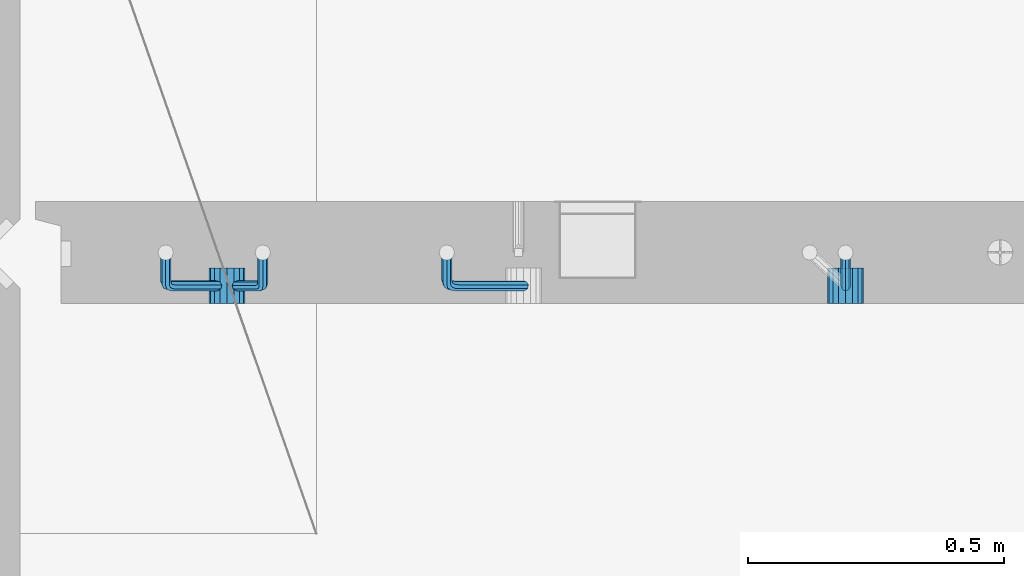
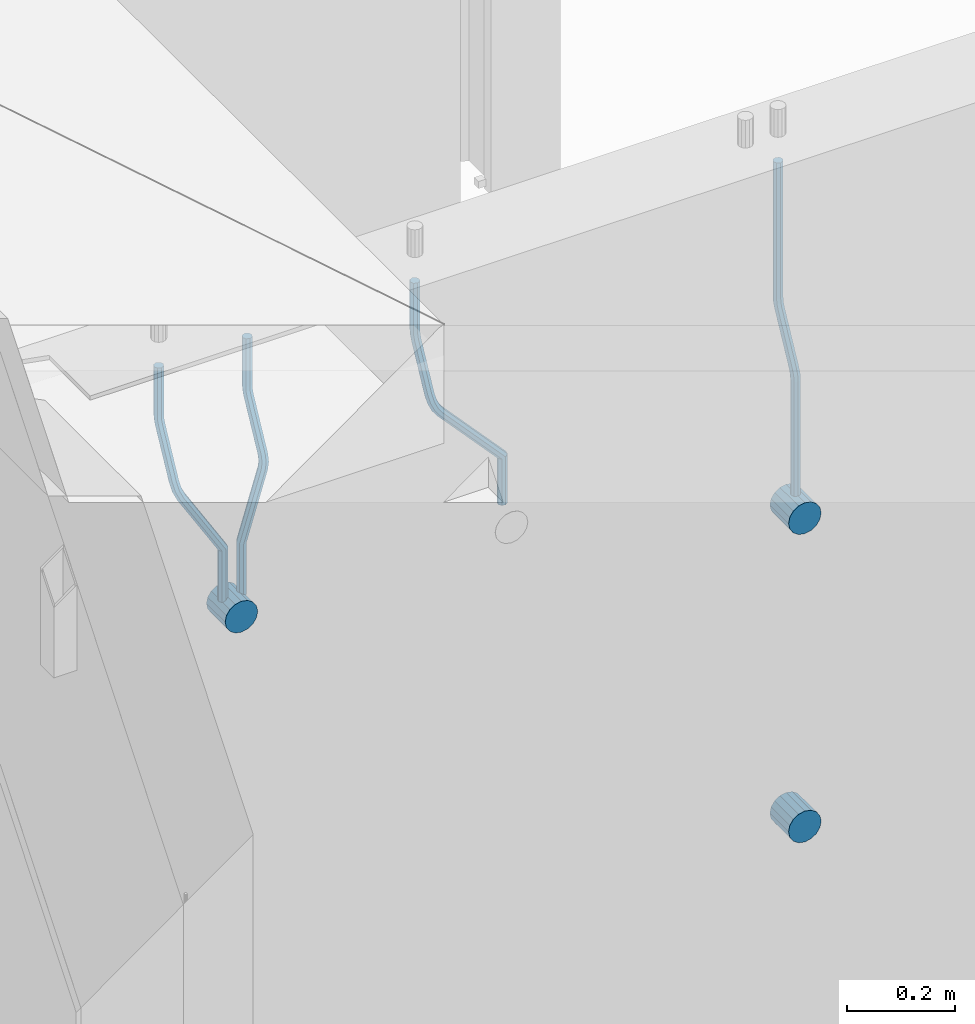
# One storey, part 130 of 309: 7 beams, 1 element without a shape of its own.
"""IFC2X3 building model written with IfcOpenShell, lengths in millimetres."""

from ifc_helpers import new_model, si_unit, frame, origin_with_axes, place, context, subcontext, project, spatial, faceted_brep, material, type_object, element, aggregate, save


model = new_model("IFC2X3")

# Units and contexts
model_context = context("Model", 3, precision=1e-05, world=origin_with_axes())
body_context = subcontext(model_context, "Body", "Model", "MODEL_VIEW")
ifc_project = project(units=[si_unit("LENGTHUNIT", "METRE", prefix="MILLI"), si_unit("AREAUNIT", "SQUARE_METRE"), si_unit("VOLUMEUNIT", "CUBIC_METRE"), si_unit("MASSUNIT", "GRAM", prefix="KILO"), si_unit("TIMEUNIT", "SECOND"), si_unit("PLANEANGLEUNIT", "RADIAN"), si_unit("SOLIDANGLEUNIT", "STERADIAN"), si_unit("THERMODYNAMICTEMPERATUREUNIT", "DEGREE_CELSIUS"), si_unit("LUMINOUSINTENSITYUNIT", "LUMEN")], contexts=[model_context])

# Site, building, storey
site_placement = place(None, origin_with_axes())
site = spatial("IfcSite", under=ifc_project, at=site_placement, CompositionType="ELEMENT")
building_placement = place(site_placement, origin_with_axes())
building = spatial("IfcBuilding", under=site, at=building_placement, CompositionType="ELEMENT")
storey_placement = place(building_placement, origin_with_axes())
storey = spatial("IfcBuildingStorey", under=building, at=storey_placement, Name="7", CompositionType="ELEMENT", Elevation=0.0)

# Assembly, beams
assembly_placement = place(storey_placement, origin_with_axes())
assembly = element("IfcElementAssembly", 1, at=assembly_placement, inside=storey, AssemblyPlace="NOTDEFINED", PredefinedType="REINFORCEMENT_UNIT")
ifc_material = material()
beam_type_1 = type_object("IfcBeamType", Name="D20", PredefinedType="NOTDEFINED")
beam_1_placement = place(assembly_placement, frame((9615.0034031366, 16979.9000008034, 102407.5), z_axis=(-0.000415599999849952, -0.999999913638316, 0.0), x_axis=(0.0, 0.0, -1.0)))
beam_1 = element("IfcBeam", 2, at=beam_1_placement, type_object=beam_type_1, material=ifc_material, Name="JM20", ObjectType="D20", context=body_context, shape_type="Brep", body=[
    faceted_brep([(0.0, -10.0, 0.0), (-4.19531716033816e-08, -7.07106781186667, -7.07106781187031), (308.817759199839, -7.07106784567077, -7.07106781098628), (308.817759199388, -10.0000000315576, 1.18961906991899e-09), (0.0, 0.0, -10.0), (308.817759200625, -3.38059180648997e-08, -9.99999999911961), (4.196772351861e-08, 7.07106781186303, -7.07106781186667), (308.817759201396, 7.07106777806075, -7.07106781098992), (0.0, 10.0, 0.0), (308.817759201687, 9.99999996619408, 8.76752892509103e-10), (4.196772351861e-08, 7.07106781185939, 7.07106781185939), (308.817759201353, 7.07106777805893, 7.07106781273978), (0.0, 0.0, 10.0), (308.817759200567, -3.38059180648997e-08, 10.0000000008768), (-4.19531716033816e-08, -7.07106781187031, 7.07106781185939), (308.817759199781, -7.07106784567259, 7.07106781274342), (323.108969574154, 0.000717635259206872, -8.27316123493802), (322.412036484602, -7.07038517474393, -5.42844102338131), (320.72809124495, -9.99940192615759, 1.43915193649809), (319.043566138222, -7.07055433041933, 8.30667482965873), (318.345233125816, 0.000478413006931078, 11.1512258851908), (319.042166215368, 7.07158122300643, 8.30650567364501), (320.726111455049, 10.0005979744237, 1.4389127137656), (322.410636561748, 7.07175037869092, -5.42861017940231), (335.221090258594, 7.07375888522984, -0.59577927861028), (336.577559329642, 0.00282932867594354, -3.19204402394098), (331.949003496353, 10.0023575726736, 5.67282516818887), (328.678043090971, 7.07309199865631, 11.9417058486688), (327.324293285914, 0.00188620863991673, 14.5386374811205), (328.680762356948, -7.06904334791398, 11.9423727357971), (331.952849119407, -9.99764203791528, 5.67376828873239), (335.223809524556, -7.06837646134409, -0.59511239150379), (438.031978881656, -7.04607830785426, 53.0582885393342), (434.761018476231, -9.97534387865016, 59.3271692200688), (439.385728686641, 0.0251274821457628, 50.4613569068679), (438.02925961549, 7.0960570387233, 53.0576216521513), (434.757172853177, 10.0246557262235, 59.326226098925), (431.486212447766, 7.0953901522571, 65.5951067794085), (430.132462642781, 0.0241843622607121, 68.1920384118748), (431.488931713931, -7.04674519431865, 65.5957736665914), (448.364788846782, 0.0265352911246737, 53.8487685030559), (447.667855771331, -7.04456751813632, 56.6934887198913), (445.983910537514, -9.97358426776555, 63.5610816819462), (444.29938542498, -7.04473667025195, 70.428604572935), (443.601052398531, 0.0262960739091795, 73.2731556232175), (444.297985473939, 7.09739888316835, 70.4284354063821), (445.981930707741, 10.0264156328012, 63.5608424443053), (447.666455820276, 7.09756803528398, 56.6933195533311), (457.892262743961, 7.0980815803614, 57.9289265681182), (457.892262772089, 0.0270137655697908, 54.999994387068), (457.892262732348, 10.0270137755506, 64.9999943770345), (457.892262744092, 7.09808159448221, 72.0710621918224), (457.89226277222, 0.0270137855477515, 74.9999943870425), (457.89226280032, -7.04405402924385, 72.0710622060069), (457.892262811918, -9.97298622770904, 64.9999943967923), (457.892262800189, -7.04405404336103, 57.9289265822954), (717.500000028129, -7.04405301280349, 57.928926581666), (717.500000039799, -9.97298519384276, 64.9999943964685), (717.499999999956, 0.0270147961218754, 54.999994386435), (717.499999971798, 7.09808261092803, 57.9289265674743), (717.499999960128, 10.0270148061572, 64.9999943763978), (717.499999971813, 7.09808262511979, 72.071062191204), (717.499999999985, 0.0270148161926045, 74.999994386435), (717.500000028143, -7.04405299861173, 72.0710622053957)], [[[0, 1, 2, 3]], [[1, 4, 5, 2]], [[4, 6, 7, 5]], [[6, 8, 9, 7]], [[8, 10, 11, 9]], [[10, 12, 13, 11]], [[12, 14, 15, 13]], [[14, 0, 3, 15]], [[14, 12, 10, 8, 6, 4, 1, 0]], [[2, 5, 16, 17]], [[3, 2, 17, 18]], [[15, 3, 18, 19]], [[13, 15, 19, 20]], [[11, 13, 20, 21]], [[9, 11, 21, 22]], [[7, 9, 22, 23]], [[5, 7, 23, 16]], [[23, 24, 25, 16]], [[22, 26, 24, 23]], [[21, 27, 26, 22]], [[20, 28, 27, 21]], [[19, 29, 28, 20]], [[18, 30, 29, 19]], [[17, 31, 30, 18]], [[16, 25, 31, 17]], [[30, 31, 32, 33]], [[31, 25, 34, 32]], [[25, 24, 35, 34]], [[24, 26, 36, 35]], [[26, 27, 37, 36]], [[27, 28, 38, 37]], [[28, 29, 39, 38]], [[29, 30, 33, 39]], [[32, 34, 40, 41]], [[33, 32, 41, 42]], [[39, 33, 42, 43]], [[38, 39, 43, 44]], [[37, 38, 44, 45]], [[36, 37, 45, 46]], [[35, 36, 46, 47]], [[34, 35, 47, 40]], [[47, 48, 49, 40]], [[46, 50, 48, 47]], [[45, 51, 50, 46]], [[44, 52, 51, 45]], [[43, 53, 52, 44]], [[42, 54, 53, 43]], [[41, 55, 54, 42]], [[40, 49, 55, 41]], [[54, 55, 56, 57]], [[55, 49, 58, 56]], [[49, 48, 59, 58]], [[48, 50, 60, 59]], [[50, 51, 61, 60]], [[51, 52, 62, 61]], [[52, 53, 63, 62]], [[53, 54, 57, 63]], [[58, 59, 60, 61, 62, 63, 57, 56]]]),
])
beam_2_placement = place(assembly_placement, frame((8835.00340324668, 16979.9000008034, 102407.5), z_axis=(-0.000415599999849952, -0.999999913638316, 0.0), x_axis=(0.0, 0.0, -1.0)))
beam_2 = element("IfcBeam", 3, at=beam_2_placement, type_object=beam_type_1, material=ifc_material, Name="JM20", ObjectType="D20", context=body_context, shape_type="Brep", body=[
    faceted_brep([(0.0, -10.0, 0.0), (-4.19531716033816e-08, -7.07106781186667, -7.07106781187031), (108.817745274035, -7.07106780534923, -7.07106781138282), (108.817745274282, -9.99999999387728, 6.25732354819775e-10), (0.0, 0.0, -10.0), (108.817745273627, 6.5174390329048e-09, -9.99999999951979), (4.196772351861e-08, 7.07106781186303, -7.07106781186667), (108.817745273191, 7.07106781838229, -7.07106781138646), (0.0, 10.0, 0.0), (108.817745272972, 10.0000000065156, 4.80213202536106e-10), (4.196772351861e-08, 7.07106781185939, 7.07106781185939), (108.817745273118, 7.07106781838047, 7.07106781234688), (0.0, 0.0, 10.0), (108.817745273511, 6.51562004350126e-09, 10.0000000004839), (-4.19531716033816e-08, -7.07106781187031, 7.07106781185939), (108.817745273947, -7.07106780535105, 7.07106781234688), (123.108954183059, 0.000717681035894202, -8.27316159443217), (122.412021172189, -7.07038512938016, -5.42844136475105), (120.72807610796, -9.99940188179062, 1.43915163770362), (119.043551170704, -7.07055428705462, 8.30667457294476), (118.345218222516, 0.000478455955089885, 11.1512256454189), (119.0421512334, 7.07158126637114, 8.30650541574869), (120.726096297614, 10.0005980187834, 1.43891241329038), (122.410621234856, 7.0717504240456, -5.42861052196531), (135.22107377628, 7.07375894905454, -0.595780608462519), (136.577542729705, 0.00282939387761871, -3.19204541917861), (131.948987323645, 10.0023576331841, 5.67282400158729), (128.678027238435, 7.07309205585807, 11.9417048475552), (127.324277576598, 0.00188626447015849, 14.5386365507547), (128.680746529979, -7.06904329070858, 11.9423717400241), (131.952832982774, -9.99764197422519, 5.67376712984333), (135.223793067897, -7.06837639751029, -0.595113715968182), (228.618473932263, -7.04811975626581, 48.1455814515648), (225.347513847039, -9.97738533437769, 54.4144622980784), (229.972223594217, 0.0230860351002775, 45.5486497482525), (228.615754640981, 7.0940155903063, 48.1449145588849), (225.343668188434, 10.0226142745032, 54.413519168902), (222.072708103209, 7.0933486972317, 60.6824000149136), (220.71895844127, 0.0221429058692593, 63.2793317182222), (222.075427394506, -7.04878664933858, 60.6830669075935), (242.359530626607, -5.11807977741773, 54.2178725378544), (240.589998539246, -7.8364579297413, 61.1502473240325), (237.467032239641, -4.88691414189452, 67.4847494116439), (234.820023031163, 2.00274883800921, 69.5107133886158), (234.199553008453, 8.79665987653607, 66.041357034137), (235.9690850958, 11.515038028856, 59.108982247948), (239.092051395462, 8.56549424101649, 52.7744801603476), (241.739060603926, 1.67583126110367, 50.7485161833647), (253.320593995435, 6.49475796966908, 54.0461912154642), (255.884193780192, 0.509358169847474, 58.0688258176233), (249.403367901468, 12.8559000820806, 55.7104792064529), (246.427173417251, 15.8665137298067, 62.0867724571763), (246.135424907392, 13.7630222690877, 69.4399248590198), (248.699024692221, 7.77762246929342, 73.462559461208), (252.616250786203, 1.41648035689104, 71.7982714702011), (255.592445270362, -1.59413329085874, 65.4219782194778), (263.775218458322, 14.0880763316163, 55.1735662778046), (268.092877162446, 9.37667043252804, 59.3853499298057), (258.711370403718, 19.6164132468075, 56.7142082202008), (255.867666511243, 22.72325639054, 63.1047886019151), (256.909909953785, 21.588659185405, 70.6017921067651), (261.227568657952, 16.8772532863513, 74.8135757587734), (266.291416712571, 11.348916371182, 73.2729338163554), (269.135120604697, 8.24207322799703, 66.8823534341354), (411.777331932535, 141.004054536572, 59.330645583992), (412.819575375106, 139.86945733149, 66.8276490888165), (407.459673228295, 145.71546043558, 55.1188619320019), (402.395825173633, 151.243797350722, 56.6595038743981), (399.552121281173, 154.350640494475, 63.0500842560868), (400.594364723744, 153.216043289394, 70.547087760915), (404.912023427984, 148.504637390388, 74.7588714129015), (409.975871482646, 142.976300475242, 73.2182294705053), (412.588360762704, 141.747027069805, 59.3303368045817), (413.18825896435, 140.207203377095, 66.8275087215443), (410.103187350978, 148.137147940774, 55.1178554785947), (407.188519608899, 155.634319848998, 56.6576791731022), (405.551730369989, 159.846801170075, 63.047800051525), (406.151628571635, 158.306977477367, 70.5449719684912), (408.636801983361, 151.916856606398, 74.7574532944818), (411.551469725426, 144.419684698174, 73.2176295999743), (413.688258959737, 141.747027073105, 59.3303368045781), (413.68825896435, 140.207203378595, 66.8275087215443), (413.688258940572, 148.137147951529, 55.1178554785911), (413.688258918075, 155.634319868494, 56.6576791730986), (413.688258905444, 159.846801194481, 63.0478000515213), (413.688258910042, 158.306977499973, 70.5449719684912), (413.688258929222, 151.916856621549, 74.7574532944782), (413.688258951704, 144.419684704584, 73.2176295999707), (517.499999574822, 141.74702738449, 59.3303368045817), (517.499999579435, 140.207203689981, 66.8275087215443), (517.499999555657, 148.137148262915, 55.1178554785947), (517.499999533175, 155.634320179879, 56.6576791731022), (517.499999520529, 159.846801505866, 63.047800051525), (517.499999525127, 158.306977811359, 70.5449719684912), (517.499999544307, 151.916856932934, 74.7574532944818), (517.499999566789, 144.41968501597, 73.2176295999743)], [[[0, 1, 2, 3]], [[1, 4, 5, 2]], [[4, 6, 7, 5]], [[6, 8, 9, 7]], [[8, 10, 11, 9]], [[10, 12, 13, 11]], [[12, 14, 15, 13]], [[14, 0, 3, 15]], [[14, 12, 10, 8, 6, 4, 1, 0]], [[2, 5, 16, 17]], [[3, 2, 17, 18]], [[15, 3, 18, 19]], [[13, 15, 19, 20]], [[11, 13, 20, 21]], [[9, 11, 21, 22]], [[7, 9, 22, 23]], [[5, 7, 23, 16]], [[23, 24, 25, 16]], [[22, 26, 24, 23]], [[21, 27, 26, 22]], [[20, 28, 27, 21]], [[19, 29, 28, 20]], [[18, 30, 29, 19]], [[17, 31, 30, 18]], [[16, 25, 31, 17]], [[30, 31, 32, 33]], [[31, 25, 34, 32]], [[25, 24, 35, 34]], [[24, 26, 36, 35]], [[26, 27, 37, 36]], [[27, 28, 38, 37]], [[28, 29, 39, 38]], [[29, 30, 33, 39]], [[33, 32, 40, 41]], [[39, 33, 41, 42]], [[38, 39, 42, 43]], [[37, 38, 43, 44]], [[36, 37, 44, 45]], [[35, 36, 45, 46]], [[34, 35, 46, 47]], [[32, 34, 47, 40]], [[47, 48, 49, 40]], [[46, 50, 48, 47]], [[45, 51, 50, 46]], [[44, 52, 51, 45]], [[43, 53, 52, 44]], [[42, 54, 53, 43]], [[41, 55, 54, 42]], [[40, 49, 55, 41]], [[48, 56, 57, 49]], [[50, 58, 56, 48]], [[51, 59, 58, 50]], [[52, 60, 59, 51]], [[53, 61, 60, 52]], [[54, 62, 61, 53]], [[55, 63, 62, 54]], [[49, 57, 63, 55]], [[63, 57, 64, 65]], [[57, 56, 66, 64]], [[56, 58, 67, 66]], [[58, 59, 68, 67]], [[59, 60, 69, 68]], [[60, 61, 70, 69]], [[61, 62, 71, 70]], [[62, 63, 65, 71]], [[65, 64, 72, 73]], [[64, 66, 74, 72]], [[66, 67, 75, 74]], [[67, 68, 76, 75]], [[68, 69, 77, 76]], [[69, 70, 78, 77]], [[70, 71, 79, 78]], [[71, 65, 73, 79]], [[73, 72, 80, 81]], [[72, 74, 82, 80]], [[74, 75, 83, 82]], [[75, 76, 84, 83]], [[76, 77, 85, 84]], [[77, 78, 86, 85]], [[78, 79, 87, 86]], [[79, 73, 81, 87]], [[81, 80, 88, 89]], [[80, 82, 90, 88]], [[82, 83, 91, 90]], [[83, 84, 92, 91]], [[84, 85, 93, 92]], [[85, 86, 94, 93]], [[86, 87, 95, 94]], [[87, 81, 89, 95]], [[90, 91, 92, 93, 94, 95, 89, 88]]]),
])
beam_3_placement = place(assembly_placement, frame((8475.00340324668, 16979.9000008034, 102407.5), z_axis=(-0.000415599999849952, -0.999999913638316, 0.0), x_axis=(0.0, 0.0, -1.0)))
beam_3 = element("IfcBeam", 4, at=beam_3_placement, type_object=beam_type_1, material=ifc_material, Name="JM20", ObjectType="D20", context=body_context, shape_type="Brep", body=[
    faceted_brep([(0.0, -10.0, 0.0), (-4.19531716033816e-08, -7.07106781186667, -7.07106781187031), (108.817745274035, -7.07106780534923, -7.07106781138282), (108.817745274282, -9.99999999387728, 6.25732354819775e-10), (0.0, 0.0, -10.0), (108.817745273627, 6.5174390329048e-09, -9.99999999951979), (4.196772351861e-08, 7.07106781186303, -7.07106781186667), (108.817745273191, 7.07106781838229, -7.07106781138646), (0.0, 10.0, 0.0), (108.817745272972, 10.0000000065156, 4.80213202536106e-10), (4.196772351861e-08, 7.07106781185939, 7.07106781185939), (108.817745273118, 7.07106781838047, 7.07106781234688), (0.0, 0.0, 10.0), (108.817745273511, 6.51562004350126e-09, 10.0000000004839), (-4.19531716033816e-08, -7.07106781187031, 7.07106781185939), (108.817745273947, -7.07106780535105, 7.07106781234688), (123.108954183059, 0.000717681035894202, -8.27316159443217), (122.412021172189, -7.07038512938016, -5.42844136475105), (120.72807610796, -9.99940188179062, 1.43915163770362), (119.043551170704, -7.07055428705462, 8.30667457294476), (118.345218222516, 0.000478455955089885, 11.1512256454189), (119.0421512334, 7.07158126637114, 8.30650541574869), (120.726096297614, 10.0005980187834, 1.43891241329038), (122.410621234856, 7.0717504240456, -5.42861052196531), (135.22107377628, 7.07375894905454, -0.595780608462519), (136.577542729705, 0.00282939387761871, -3.19204541917861), (131.948987323645, 10.0023576331841, 5.67282400158729), (128.678027238435, 7.07309205585807, 11.9417048475552), (127.324277576598, 0.00188626447015849, 14.5386365507547), (128.680746529979, -7.06904329070858, 11.9423717400241), (131.952832982774, -9.99764197422519, 5.67376712984333), (135.223793067897, -7.06837639751029, -0.595113715968182), (236.184987141853, -7.04647863304126, 52.0943835719445), (232.914027056744, -9.97574421112949, 58.3632644184945), (237.538736803792, 0.0247271583230031, 49.4974518686358), (236.182267850556, 7.09565671352902, 52.093716679261), (232.910181397994, 10.0242553977168, 58.3623212892744), (229.639221312784, 7.0949898204417, 64.631202135286), (228.28547165083, 0.0237840290774329, 67.2281338385947), (229.64194060408, -7.04714552612859, 64.6318690279659), (248.6361426574, 6.07228546495571, 56.8411920703111), (248.347225361111, -0.863437898962729, 53.6176983169717), (246.616285773896, -7.90364889308694, 56.0708434545886), (244.457284830249, -10.9242873990424, 62.7636083320067), (243.134936001807, -8.15590434705155, 69.7754620538217), (243.423853298023, -1.22018098313129, 72.9989558071647), (245.154792885252, 5.82003001100384, 70.5458106695442), (247.313793828915, 8.84066851695206, 63.8530457921224), (262.262810178814, 5.37582167724941, 65.733133839356), (261.561593060862, 3.07645584421334, 58.4667829613572), (261.257873569193, 2.08769693226714, 72.5710415482208), (259.135461468584, -4.86177950991259, 74.9749524903455), (257.138854100602, -11.4016986008392, 71.5366882385752), (256.437636982591, -13.7010644331713, 64.2703373600561), (257.442573592241, -10.4129396888893, 57.4324296517152), (259.564985692865, -3.46346324671867, 55.0285187095906), (405.56030258059, -55.6424869289785, 57.4512270528103), (404.555365971013, -58.9306116739535, 64.2891347616751), (407.682714681185, -48.6930104868225, 55.0473161106529), (409.679322049255, -42.153091395905, 58.4855803623905), (410.380539167294, -39.8537255628671, 65.7519312403674), (409.375602557717, -43.1418503078439, 72.5898389492322), (407.253190457122, -50.09132675, 74.993749891386), (405.256583089053, -56.6312458409175, 71.5554856396557), (408.394915116543, -56.5080702894629, 57.4515867892878), (407.881249744809, -59.9462106727442, 64.2895568446584), (409.479769216079, -49.2417629119063, 55.0475441721828), (410.500319225088, -42.4037928534744, 58.4856845539216), (410.858740789379, -39.9997502352981, 65.751991928224), (410.345075417616, -43.4378906185757, 72.5899619835945), (409.26022131808, -50.7041979961323, 74.9940046006996), (408.239671309086, -57.5421680545642, 71.5558642189608), (411.358740838899, -56.5080702805735, 57.4515867892915), (411.358740849202, -59.9462106623123, 64.2895568446584), (411.358740817101, -49.2417629062693, 55.0475441721828), (411.358740796582, -42.4037928508988, 58.4856845539216), (411.358740789379, -39.9997502337974, 65.751991928224), (411.358740799667, -43.4378906155343, 72.5899619835945), (411.358740821452, -50.7041979898386, 74.9940046006996), (411.35874084197, -57.5421680452091, 71.5558642189608), (527.500000169515, -56.5080699322043, 57.4515867892878), (527.500000179818, -59.9462103139449, 64.2895568446584), (527.500000147716, -49.2417625579019, 55.0475441721828), (527.500000127198, -42.4037925025295, 58.4856845539216), (527.500000119981, -39.9997498854282, 65.751991928224), (527.500000130283, -43.4378902671669, 72.5899619835945), (527.500000152068, -50.7041976414694, 74.9940046006996), (527.500000172586, -57.5421676968399, 71.5558642189608)], [[[0, 1, 2, 3]], [[1, 4, 5, 2]], [[4, 6, 7, 5]], [[6, 8, 9, 7]], [[8, 10, 11, 9]], [[10, 12, 13, 11]], [[12, 14, 15, 13]], [[14, 0, 3, 15]], [[14, 12, 10, 8, 6, 4, 1, 0]], [[2, 5, 16, 17]], [[3, 2, 17, 18]], [[15, 3, 18, 19]], [[13, 15, 19, 20]], [[11, 13, 20, 21]], [[9, 11, 21, 22]], [[7, 9, 22, 23]], [[5, 7, 23, 16]], [[23, 24, 25, 16]], [[22, 26, 24, 23]], [[21, 27, 26, 22]], [[20, 28, 27, 21]], [[19, 29, 28, 20]], [[18, 30, 29, 19]], [[17, 31, 30, 18]], [[16, 25, 31, 17]], [[30, 31, 32, 33]], [[31, 25, 34, 32]], [[25, 24, 35, 34]], [[24, 26, 36, 35]], [[26, 27, 37, 36]], [[27, 28, 38, 37]], [[28, 29, 39, 38]], [[29, 30, 33, 39]], [[34, 35, 40, 41]], [[32, 34, 41, 42]], [[33, 32, 42, 43]], [[39, 33, 43, 44]], [[38, 39, 44, 45]], [[37, 38, 45, 46]], [[36, 37, 46, 47]], [[35, 36, 47, 40]], [[47, 48, 49, 40]], [[46, 50, 48, 47]], [[45, 51, 50, 46]], [[44, 52, 51, 45]], [[43, 53, 52, 44]], [[42, 54, 53, 43]], [[41, 55, 54, 42]], [[40, 49, 55, 41]], [[53, 54, 56, 57]], [[54, 55, 58, 56]], [[55, 49, 59, 58]], [[49, 48, 60, 59]], [[48, 50, 61, 60]], [[50, 51, 62, 61]], [[51, 52, 63, 62]], [[52, 53, 57, 63]], [[57, 56, 64, 65]], [[56, 58, 66, 64]], [[58, 59, 67, 66]], [[59, 60, 68, 67]], [[60, 61, 69, 68]], [[61, 62, 70, 69]], [[62, 63, 71, 70]], [[63, 57, 65, 71]], [[65, 64, 72, 73]], [[64, 66, 74, 72]], [[66, 67, 75, 74]], [[67, 68, 76, 75]], [[68, 69, 77, 76]], [[69, 70, 78, 77]], [[70, 71, 79, 78]], [[71, 65, 73, 79]], [[73, 72, 80, 81]], [[72, 74, 82, 80]], [[74, 75, 83, 82]], [[75, 76, 84, 83]], [[76, 77, 85, 84]], [[77, 78, 86, 85]], [[78, 79, 87, 86]], [[79, 73, 81, 87]], [[82, 83, 84, 85, 86, 87, 81, 80]]]),
])
beam_4_placement = place(assembly_placement, frame((8285.00340324668, 16979.9000008034, 102407.5), z_axis=(-0.000415599999849952, -0.999999913638316, 0.0), x_axis=(0.0, 0.0, -1.0)))
beam_4 = element("IfcBeam", 5, at=beam_4_placement, type_object=beam_type_1, material=ifc_material, Name="JM20", ObjectType="D20", context=body_context, shape_type="Brep", body=[
    faceted_brep([(0.0, -10.0, 0.0), (-4.19531716033816e-08, -7.07106781186667, -7.07106781187031), (108.817745274035, -7.07106780534923, -7.07106781138282), (108.817745274282, -9.99999999387728, 6.25732354819775e-10), (0.0, 0.0, -10.0), (108.817745273627, 6.5174390329048e-09, -9.99999999951979), (4.196772351861e-08, 7.07106781186303, -7.07106781186667), (108.817745273191, 7.07106781838229, -7.07106781138646), (0.0, 10.0, 0.0), (108.817745272972, 10.0000000065156, 4.80213202536106e-10), (4.196772351861e-08, 7.07106781185939, 7.07106781185939), (108.817745273118, 7.07106781838047, 7.07106781234688), (0.0, 0.0, 10.0), (108.817745273511, 6.51562004350126e-09, 10.0000000004839), (-4.19531716033816e-08, -7.07106781187031, 7.07106781185939), (108.817745273947, -7.07106780535105, 7.07106781234688), (123.108954183059, 0.000717681035894202, -8.27316159443217), (122.412021172189, -7.07038512938016, -5.42844136475105), (120.72807610796, -9.99940188179062, 1.43915163770362), (119.043551170704, -7.07055428705462, 8.30667457294476), (118.345218222516, 0.000478455955089885, 11.1512256454189), (119.0421512334, 7.07158126637114, 8.30650541574869), (120.726096297614, 10.0005980187834, 1.43891241329038), (122.410621234856, 7.0717504240456, -5.42861052196531), (135.22107377628, 7.07375894905454, -0.595780608462519), (136.577542729705, 0.00282939387761871, -3.19204541917861), (131.948987323645, 10.0023576331841, 5.67282400158729), (128.678027238435, 7.07309205585807, 11.9417048475552), (127.324277576598, 0.00188626447015849, 14.5386365507547), (128.680746529979, -7.06904329070858, 11.9423717400241), (131.952832982774, -9.99764197422519, 5.67376712984333), (135.223793067897, -7.06837639751029, -0.595113715968182), (232.402437428042, -7.04729904112355, 50.1203514230874), (229.131477342933, -9.97656461926999, 56.3892322695465), (233.756187089995, 0.0239067502407124, 47.5234197197824), (232.399718136745, 7.09483630544673, 50.1196845304112), (229.127631684183, 10.0234349896364, 56.3882891404246), (225.856671598973, 7.09416941235941, 62.6571699864289), (224.502921937034, 0.0229636209951423, 65.2541016897412), (225.859390890269, -7.04796593420906, 62.6578368791124), (249.189096393879, -4.47246690703469, 56.6819566015656), (248.077205390815, -7.070562329116, 63.794778990592), (245.438615273073, -4.04479441522199, 70.3110060036124), (242.818976346156, 2.83238302726022, 72.4135202319376), (241.752837564854, 9.53241272338892, 68.8706973556764), (242.864728567991, 12.130508145472, 61.7578749666827), (245.503318685674, 9.10474023159077, 55.2416479536478), (248.122957612577, 2.22756278908673, 53.1391337253044), (262.227655998417, 8.55574368060479, 55.0905560343417), (265.66954071114, 2.92161058118472, 58.9620696407692), (258.367889273839, 14.876528294435, 57.021495303452), (256.351239537093, 18.1813345207174, 63.6237694123665), (257.359032853405, 16.5342516931214, 71.0298557306051), (260.800917566128, 10.9001185936977, 74.9013693370434), (264.660684290735, 4.57933397990018, 72.9704300679259), (266.677334027001, 1.27452775464917, 66.3681559586585), (410.721160764631, 91.5081613346811, 58.9252530669619), (411.728954081002, 89.861078507096, 66.3313393852004), (407.279276051908, 97.1422944340902, 55.053739460498), (403.419509327403, 103.46307904791, 56.9846787295719), (401.402859590729, 106.767885274196, 63.5869528384683), (402.410652907114, 105.12080244661, 70.9930391567141), (405.852537619838, 99.4866693472013, 74.8645527631779), (409.712304344357, 93.1658847333838, 72.9336134941077), (411.611923002652, 92.0521714889783, 58.9250269763252), (412.155668410225, 90.1216833219078, 66.3312310778347), (409.754886469877, 98.6542099015223, 55.0531111083837), (407.672385626982, 106.060413996784, 56.9835992770786), (406.584321224072, 109.932329861462, 63.5856376951961), (407.12806663166, 108.001841694397, 70.9918417967092), (408.985103164436, 101.399803281851, 74.8637576646506), (411.06760400733, 93.9935991865859, 72.9332694959521), (412.655668404448, 92.0521714921069, 58.9250269763288), (412.655668410225, 90.1216833234084, 66.3312310778347), (412.655668384643, 98.6542099102207, 55.0531111083837), (412.655668362422, 106.06041401173, 56.9835992770822), (412.65566835081, 109.932329879672, 63.5856376951961), (412.655668356587, 108.001841710977, 70.9918417967056), (412.655668376392, 101.399803292861, 74.8637576646506), (412.655668398613, 93.9935991913499, 72.9332694959521), (527.499999723892, 92.0521718365853, 58.9250269763252), (527.499999729669, 90.1216836678886, 66.3312310778347), (527.499999704101, 98.6542102546991, 55.0531111083837), (527.499999681881, 106.060414356209, 56.9835992770786), (527.499999670254, 109.93233022415, 63.5856376951924), (527.499999676045, 108.001842055455, 70.9918417967056), (527.499999695836, 101.399803637341, 74.863757664647), (527.499999718057, 93.9935995358301, 72.9332694959521)], [[[0, 1, 2, 3]], [[1, 4, 5, 2]], [[4, 6, 7, 5]], [[6, 8, 9, 7]], [[8, 10, 11, 9]], [[10, 12, 13, 11]], [[12, 14, 15, 13]], [[14, 0, 3, 15]], [[14, 12, 10, 8, 6, 4, 1, 0]], [[2, 5, 16, 17]], [[3, 2, 17, 18]], [[15, 3, 18, 19]], [[13, 15, 19, 20]], [[11, 13, 20, 21]], [[9, 11, 21, 22]], [[7, 9, 22, 23]], [[5, 7, 23, 16]], [[23, 24, 25, 16]], [[22, 26, 24, 23]], [[21, 27, 26, 22]], [[20, 28, 27, 21]], [[19, 29, 28, 20]], [[18, 30, 29, 19]], [[17, 31, 30, 18]], [[16, 25, 31, 17]], [[30, 31, 32, 33]], [[31, 25, 34, 32]], [[25, 24, 35, 34]], [[24, 26, 36, 35]], [[26, 27, 37, 36]], [[27, 28, 38, 37]], [[28, 29, 39, 38]], [[29, 30, 33, 39]], [[33, 32, 40, 41]], [[39, 33, 41, 42]], [[38, 39, 42, 43]], [[37, 38, 43, 44]], [[36, 37, 44, 45]], [[35, 36, 45, 46]], [[34, 35, 46, 47]], [[32, 34, 47, 40]], [[47, 48, 49, 40]], [[46, 50, 48, 47]], [[45, 51, 50, 46]], [[44, 52, 51, 45]], [[43, 53, 52, 44]], [[42, 54, 53, 43]], [[41, 55, 54, 42]], [[40, 49, 55, 41]], [[55, 49, 56, 57]], [[49, 48, 58, 56]], [[48, 50, 59, 58]], [[50, 51, 60, 59]], [[51, 52, 61, 60]], [[52, 53, 62, 61]], [[53, 54, 63, 62]], [[54, 55, 57, 63]], [[57, 56, 64, 65]], [[56, 58, 66, 64]], [[58, 59, 67, 66]], [[59, 60, 68, 67]], [[60, 61, 69, 68]], [[61, 62, 70, 69]], [[62, 63, 71, 70]], [[63, 57, 65, 71]], [[65, 64, 72, 73]], [[64, 66, 74, 72]], [[66, 67, 75, 74]], [[67, 68, 76, 75]], [[68, 69, 77, 76]], [[69, 70, 78, 77]], [[70, 71, 79, 78]], [[71, 65, 73, 79]], [[73, 72, 80, 81]], [[72, 74, 82, 80]], [[74, 75, 83, 82]], [[75, 76, 84, 83]], [[76, 77, 85, 84]], [[77, 78, 86, 85]], [[78, 79, 87, 86]], [[79, 73, 81, 87]], [[82, 83, 84, 85, 86, 87, 81, 80]]]),
])
beam_type_2 = type_object("IfcBeamType", Name="D70", PredefinedType="NOTDEFINED")
beam_5_placement = place(assembly_placement, frame((9615.00340323833, 16879.9000008034, 101654.999998963), z_axis=(0.0, 0.0, 1.0), x_axis=(0.0, 1.0, 0.0)))
beam_5 = element("IfcBeam", 6, at=beam_5_placement, type_object=beam_type_2, material=ifc_material, ObjectType="D70", context=body_context, shape_type="Brep", body=[
    faceted_brep([(0.0, -35.0, 0.0), (0.0, -32.3357836378964, -13.3939201327739), (70.0, -32.3357836378964, -13.3939201327739), (70.0, -35.0, 0.0), (0.0, -24.7487373415279, -24.7487373415352), (70.0, -24.7487373415279, -24.7487373415352), (0.0, -13.3939201327776, -32.3357836379), (70.0, -13.3939201327776, -32.3357836379), (0.0, 0.0, -35.0), (70.0, 0.0, -35.0), (0.0, 13.3939201327776, -32.3357836379), (70.0, 13.3939201327776, -32.3357836379), (0.0, 24.7487373415279, -24.7487373415352), (70.0, 24.7487373415279, -24.7487373415352), (0.0, 32.3357836378964, -13.3939201327739), (70.0, 32.3357836378964, -13.3939201327739), (0.0, 35.0, 0.0), (70.0, 35.0, 0.0), (0.0, 32.3357836378964, 13.3939201327739), (70.0, 32.3357836378964, 13.3939201327739), (0.0, 24.7487373415279, 24.7487373415352), (70.0, 24.7487373415279, 24.7487373415352), (0.0, 13.3939201327776, 32.3357836379), (70.0, 13.3939201327776, 32.3357836379), (0.0, 0.0, 35.0), (70.0, 0.0, 35.0), (0.0, -13.3939201327776, 32.3357836379), (70.0, -13.3939201327776, 32.3357836379), (0.0, -24.7487373415279, 24.7487373415352), (70.0, -24.7487373415279, 24.7487373415352), (0.0, -32.3357836378964, 13.3939201327739), (70.0, -32.3357836378964, 13.3939201327739)], [[[0, 1, 2, 3]], [[1, 4, 5, 2]], [[4, 6, 7, 5]], [[6, 8, 9, 7]], [[8, 10, 11, 9]], [[10, 12, 13, 11]], [[12, 14, 15, 13]], [[14, 16, 17, 15]], [[16, 18, 19, 17]], [[18, 20, 21, 19]], [[20, 22, 23, 21]], [[22, 24, 25, 23]], [[24, 26, 27, 25]], [[26, 28, 29, 27]], [[28, 30, 31, 29]], [[30, 0, 3, 31]], [[5, 7, 9, 11, 13, 15, 17, 19, 21, 23, 25, 27, 29, 31, 3, 2]], [[30, 28, 26, 24, 22, 20, 18, 16, 14, 12, 10, 8, 6, 4, 1, 0]]]),
])
beam_6_placement = place(assembly_placement, frame((9615.00340323833, 16879.9000008034, 100954.999998963), z_axis=(0.0, 0.0, 1.0), x_axis=(0.0, 1.0, 0.0)))
beam_6 = element("IfcBeam", 7, at=beam_6_placement, type_object=beam_type_2, material=ifc_material, ObjectType="D70", context=body_context, shape_type="Brep", body=[
    faceted_brep([(0.0, -35.0, 0.0), (0.0, -32.3357836378964, -13.3939201327739), (70.0, -32.3357836378964, -13.3939201327739), (70.0, -35.0, 0.0), (0.0, -24.7487373415279, -24.7487373415352), (70.0, -24.7487373415279, -24.7487373415352), (0.0, -13.3939201327776, -32.3357836379), (70.0, -13.3939201327776, -32.3357836379), (0.0, 0.0, -35.0), (70.0, 0.0, -35.0), (0.0, 13.3939201327776, -32.3357836379), (70.0, 13.3939201327776, -32.3357836379), (0.0, 24.7487373415279, -24.7487373415352), (70.0, 24.7487373415279, -24.7487373415352), (0.0, 32.3357836378964, -13.3939201327739), (70.0, 32.3357836378964, -13.3939201327739), (0.0, 35.0, 0.0), (70.0, 35.0, 0.0), (0.0, 32.3357836378964, 13.3939201327739), (70.0, 32.3357836378964, 13.3939201327739), (0.0, 24.7487373415279, 24.7487373415352), (70.0, 24.7487373415279, 24.7487373415352), (0.0, 13.3939201327776, 32.3357836379), (70.0, 13.3939201327776, 32.3357836379), (0.0, 0.0, 35.0), (70.0, 0.0, 35.0), (0.0, -13.3939201327776, 32.3357836379), (70.0, -13.3939201327776, 32.3357836379), (0.0, -24.7487373415279, 24.7487373415352), (70.0, -24.7487373415279, 24.7487373415352), (0.0, -32.3357836378964, 13.3939201327739), (70.0, -32.3357836378964, 13.3939201327739)], [[[0, 1, 2, 3]], [[1, 4, 5, 2]], [[4, 6, 7, 5]], [[6, 8, 9, 7]], [[8, 10, 11, 9]], [[10, 12, 13, 11]], [[12, 14, 15, 13]], [[14, 16, 17, 15]], [[16, 18, 19, 17]], [[18, 20, 21, 19]], [[20, 22, 23, 21]], [[22, 24, 25, 23]], [[24, 26, 27, 25]], [[26, 28, 29, 27]], [[28, 30, 31, 29]], [[30, 0, 3, 31]], [[5, 7, 9, 11, 13, 15, 17, 19, 21, 23, 25, 27, 29, 31, 3, 2]], [[30, 28, 26, 24, 22, 20, 18, 16, 14, 12, 10, 8, 6, 4, 1, 0]]]),
])
beam_7_placement = place(assembly_placement, frame((8405.00340323833, 16879.9000008034, 101854.999998963), z_axis=(0.0, 0.0, 1.0), x_axis=(0.0, 1.0, 0.0)))
beam_7 = element("IfcBeam", 8, at=beam_7_placement, type_object=beam_type_2, material=ifc_material, ObjectType="D70", context=body_context, shape_type="Brep", body=[
    faceted_brep([(0.0, -35.0, 0.0), (0.0, -32.3357836378964, -13.3939201327739), (70.0, -32.3357836378964, -13.3939201327739), (70.0, -35.0, 0.0), (0.0, -24.7487373415279, -24.7487373415352), (70.0, -24.7487373415279, -24.7487373415352), (0.0, -13.3939201327776, -32.3357836379), (70.0, -13.3939201327776, -32.3357836379), (0.0, 0.0, -35.0), (70.0, 0.0, -35.0), (0.0, 13.3939201327776, -32.3357836379), (70.0, 13.3939201327776, -32.3357836379), (0.0, 24.7487373415279, -24.7487373415352), (70.0, 24.7487373415279, -24.7487373415352), (0.0, 32.3357836378964, -13.3939201327739), (70.0, 32.3357836378964, -13.3939201327739), (0.0, 35.0, 0.0), (70.0, 35.0, 0.0), (0.0, 32.3357836378964, 13.3939201327739), (70.0, 32.3357836378964, 13.3939201327739), (0.0, 24.7487373415279, 24.7487373415352), (70.0, 24.7487373415279, 24.7487373415352), (0.0, 13.3939201327776, 32.3357836379), (70.0, 13.3939201327776, 32.3357836379), (0.0, 0.0, 35.0), (70.0, 0.0, 35.0), (0.0, -13.3939201327776, 32.3357836379), (70.0, -13.3939201327776, 32.3357836379), (0.0, -24.7487373415279, 24.7487373415352), (70.0, -24.7487373415279, 24.7487373415352), (0.0, -32.3357836378964, 13.3939201327739), (70.0, -32.3357836378964, 13.3939201327739)], [[[0, 1, 2, 3]], [[1, 4, 5, 2]], [[4, 6, 7, 5]], [[6, 8, 9, 7]], [[8, 10, 11, 9]], [[10, 12, 13, 11]], [[12, 14, 15, 13]], [[14, 16, 17, 15]], [[16, 18, 19, 17]], [[18, 20, 21, 19]], [[20, 22, 23, 21]], [[22, 24, 25, 23]], [[24, 26, 27, 25]], [[26, 28, 29, 27]], [[28, 30, 31, 29]], [[30, 0, 3, 31]], [[5, 7, 9, 11, 13, 15, 17, 19, 21, 23, 25, 27, 29, 31, 3, 2]], [[30, 28, 26, 24, 22, 20, 18, 16, 14, 12, 10, 8, 6, 4, 1, 0]]]),
])
aggregate(assembly, [beam_5, beam_1, beam_6, beam_2, beam_3, beam_7, beam_4])

save(model, "model.ifc")
